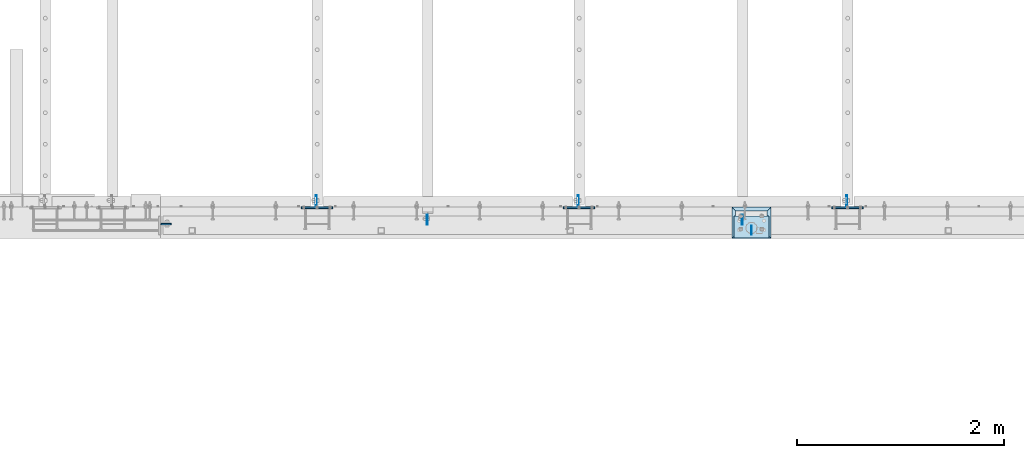
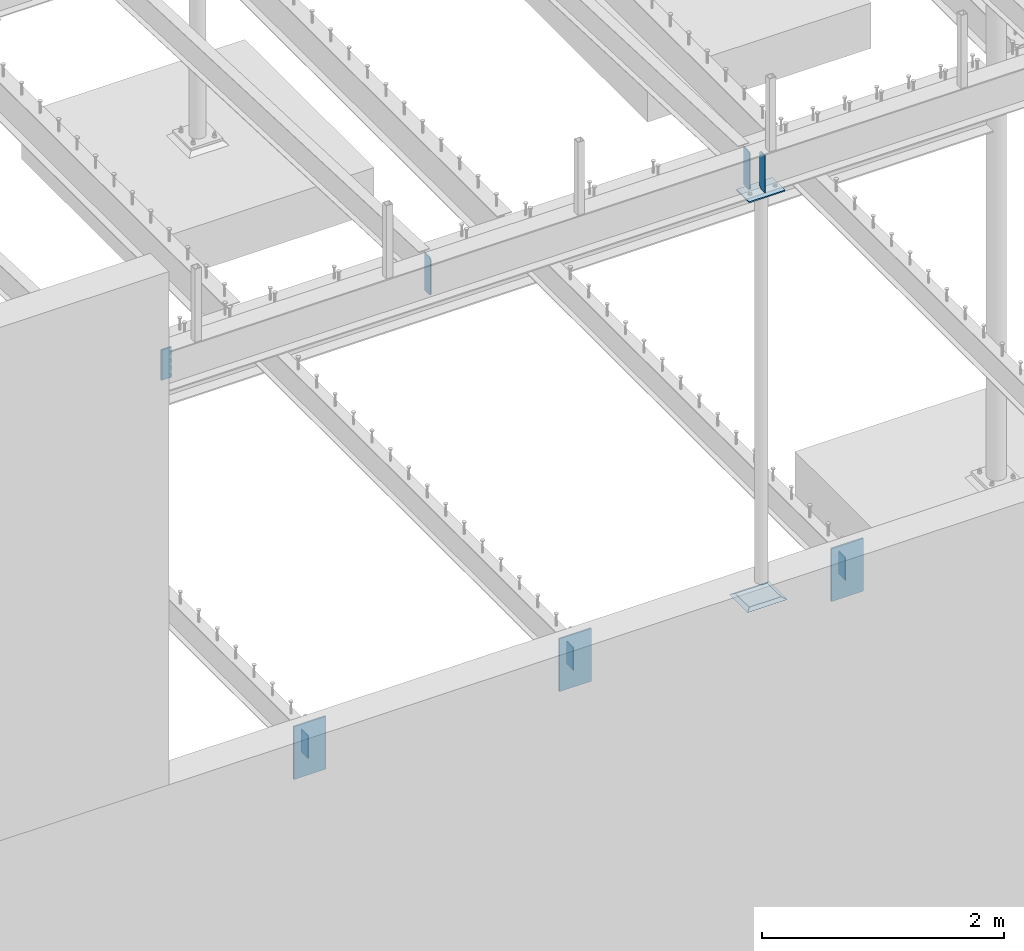
# One storey, part 847 of 975: 12 plates.
"""IFC2X3 building model written with IfcOpenShell, lengths in millimetres."""

from ifc_helpers import new_model, si_unit, frame, origin_with_axes, place, context, subcontext, project, spatial, faceted_brep, material, type_object, element, save


model = new_model("IFC2X3")

# Units and contexts
model_context = context("Model", 3, precision=1e-05, world=origin_with_axes())
body_context = subcontext(model_context, "Body", "Model", "MODEL_VIEW")
ifc_project = project(units=[si_unit("LENGTHUNIT", "METRE", prefix="MILLI"), si_unit("AREAUNIT", "SQUARE_METRE"), si_unit("VOLUMEUNIT", "CUBIC_METRE"), si_unit("MASSUNIT", "GRAM", prefix="KILO"), si_unit("TIMEUNIT", "SECOND"), si_unit("PLANEANGLEUNIT", "RADIAN"), si_unit("SOLIDANGLEUNIT", "STERADIAN"), si_unit("THERMODYNAMICTEMPERATUREUNIT", "DEGREE_CELSIUS"), si_unit("LUMINOUSINTENSITYUNIT", "LUMEN")], contexts=[model_context])

# Site, building, storey
site_placement = place(None, origin_with_axes())
site = spatial("IfcSite", under=ifc_project, at=site_placement, CompositionType="ELEMENT")
building_placement = place(site_placement, origin_with_axes())
building = spatial("IfcBuilding", under=site, at=building_placement, Name="Undefined", CompositionType="ELEMENT")
storey_placement = place(building_placement, origin_with_axes())
storey = spatial("IfcBuildingStorey", under=building, at=storey_placement, Name="Undefined", CompositionType="ELEMENT", Elevation=0.0)

# Plates
ifc_material_1 = material(Name="STEEL/A36")
plate_type_1 = type_object("IfcPlateType", PredefinedType="NOTDEFINED")
for number, where, z_axis, x_axis, name in (
    (1, (14550.2307500839, 130.96875, 8066.68070975216), (0.0, 0.0, 1.0), (0.0, 1.0, 0.0), "PLATE"),
    (2, (17598.2307500839, 130.96875, 8066.68070975215), (0.0, 0.0, 1.0), (0.0, 1.0, 0.0), "PLATE"),
):
    element("IfcPlate", number, at=place(storey_placement, frame(where, z_axis=z_axis, x_axis=x_axis)), inside=storey, type_object=plate_type_1, material=ifc_material_1, Name=name, context=body_context, shape_type="Brep", body=[
        faceted_brep([(0.0, -4.76250000000073, 17.4624996185303), (0.0, -4.76250000000073, 362.944299697877), (0.0, 4.76250000000073, 362.944299697877), (0.0, 4.76250000000073, 17.4624996185303), (17.4624996185303, -4.76250000000073, 380.406799316407), (17.4624996185303, 4.76250000000073, 380.406799316407), (98.4250030517578, -4.76250000000073, 380.406799316407), (98.4250030517578, 4.76250000000073, 380.406799316407), (98.4250030518451, -4.76250000006985, -2.36468622460961e-11), (98.4250030518597, 4.76249999992069, -2.36468622460961e-11), (17.4624996185303, -4.76250000000073, 0.0), (17.4624996185303, 4.76250000000073, 0.0)], [[[0, 1, 2, 3]], [[1, 4, 5, 2]], [[4, 6, 7, 5]], [[6, 8, 9, 7]], [[8, 10, 11, 9]], [[10, 0, 3, 11]], [[5, 7, 9, 11, 3, 2]], [[10, 8, 6, 4, 1, 0]]]),
    ])
plate_type_2 = type_object("IfcPlateType", PredefinedType="NOTDEFINED")
plate_1_placement = place(storey_placement, frame((17687.9249973829, 123.03125, 8447.0875), z_axis=(0.0, 0.0, -1.0), x_axis=(0.0, -1.0, 0.0)))
element("IfcPlate", 3, at=plate_1_placement, inside=storey, type_object=plate_type_2, material=ifc_material_1, Name="PLATE", context=body_context, shape_type="Brep", body=[
    faceted_brep([(0.0, -3.17499999999927, 19.0499992370605), (0.0, -3.17499999999927, 361.950000762939), (0.0, 3.17499999999927, 361.950000762939), (0.0, 3.17499999999927, 19.0499992370605), (19.0499992370605, -3.17499999999927, 381.0), (19.0499992370605, 3.17499999999927, 381.0), (84.9312515258789, -3.17499999999927, 381.0), (84.9312515258789, 3.17499999999927, 381.0), (84.9312515258789, -3.17499999999927, 0.0), (84.9312515258789, 3.17499999999927, 0.0), (19.0499992370605, -3.17499999999927, 0.0), (19.0499992370605, 3.17499999999927, 0.0)], [[[0, 1, 2, 3]], [[1, 4, 5, 2]], [[4, 6, 7, 5]], [[6, 8, 9, 7]], [[8, 10, 11, 9]], [[10, 0, 3, 11]], [[5, 7, 9, 11, 3, 2]], [[10, 8, 6, 4, 1, 0]]]),
])
plate_type_3 = type_object("IfcPlateType", PredefinedType="NOTDEFINED")
plate_2_placement = place(storey_placement, frame((11972.9250113505, 138.90625, 8420.1), z_axis=(1.0, 0.0, 0.0), x_axis=(0.0, 0.0, -1.0)))
element("IfcPlate", 4, at=plate_2_placement, inside=storey, type_object=plate_type_3, material=ifc_material_1, Name="PLATE", context=body_context, shape_type="Brep", body=[
    faceted_brep([(0.0, -7.9375, 7.93699979782104), (0.0, 0.000750202179915505, 0.0), (304.799987792969, 0.000750202179915505, 0.0), (304.799987792969, -7.9375, 7.93699979782104), (304.799987792969, 7.9375, 7.93699979782104), (0.0, 7.9375, 7.93699979782104), (0.0, -7.9375, 101.599998474121), (0.0, 7.9375, 101.599998474121), (304.799987792969, -7.9375, 101.599998474121), (304.799987792969, 7.9375, 101.599998474121)], [[[0, 1, 2, 3]], [[4, 2, 1, 5]], [[6, 7, 5, 1, 0]], [[6, 8, 9, 7]], [[4, 9, 8, 3, 2]], [[7, 9, 4, 5]], [[8, 6, 0, 3]]]),
])
plate_type_4 = type_object("IfcPlateType", PredefinedType="NOTDEFINED")
for number, where, z_axis, x_axis, name in (
    (5, (18610.2625, 304.8, 3898.9), (0.0, 1.0, 0.0), (0.0, 0.0, -1.0), "PLATE"),
    (6, (16013.1125, 304.8, 3898.9), (0.0, 1.0, 0.0), (0.0, 0.0, -1.0), "PLATE"),
    (7, (13479.4625, 304.799999999997, 3898.9), (0.0, 1.0, 0.0), (0.0, 0.0, -1.0), "PLATE"),
):
    element("IfcPlate", number, at=place(storey_placement, frame(where, z_axis=z_axis, x_axis=x_axis)), inside=storey, type_object=plate_type_4, material=ifc_material_1, Name=name, context=body_context, shape_type="Brep", body=[
        faceted_brep([(0.0, -4.76250000000073, 0.0), (0.0, -4.76249999999982, 114.300003051758), (0.0, 4.76249999999982, 114.300003051758), (0.0, 4.76250000000073, 0.0), (228.600006103516, -4.76250000000073, 114.300003051758), (228.600006103516, 4.76250000000073, 114.300003051758), (228.599990844727, -4.76249999999982, 0.0), (228.599990844727, 4.76250000000027, -7.27595761418343e-12)], [[[0, 1, 2, 3]], [[1, 4, 5, 2]], [[4, 6, 7, 5]], [[6, 0, 3, 7]], [[5, 7, 3, 2]], [[6, 4, 1, 0]]]),
    ])
plate_type_5 = type_object("IfcPlateType", PredefinedType="NOTDEFINED")
for number, where, z_axis, x_axis, name in (
    (8, (18465.8, 296.8625, 4048.125), (0.0, 0.0, -1.0), (1.0, 0.0, 0.0), "EMBED"),
    (9, (15868.65, 296.8625, 4048.125), (0.0, 0.0, -1.0), (1.0, 0.0, 0.0), "EMBED"),
    (10, (13335.0, 296.862499999996, 4048.125), (0.0, 0.0, -1.0), (1.0, 0.0, 0.0), "EMBED"),
):
    element("IfcPlate", number, at=place(storey_placement, frame(where, z_axis=z_axis, x_axis=x_axis)), inside=storey, type_object=plate_type_5, material=ifc_material_1, Name=name, context=body_context, shape_type="Brep", body=[
        faceted_brep([(-4.22995071858168e-07, -7.93750000000728, 0.0), (0.0, -7.9375, 533.400024414062), (0.0, 7.9375, 533.400024414062), (4.22980519942939e-07, 7.93750000001091, 0.0), (304.799987792969, -7.9375, 533.400024414062), (304.799987792969, 7.9375, 533.400024414062), (304.799987792969, -7.9375, 0.0), (304.799987792969, 7.9375, 0.0)], [[[0, 1, 2, 3]], [[1, 4, 5, 2]], [[4, 6, 7, 5]], [[6, 0, 3, 7]], [[5, 7, 3, 2]], [[6, 4, 1, 0]]]),
    ])
plate_type_6 = type_object("IfcPlateType", PredefinedType="NOTDEFINED")
plate_3_placement = place(storey_placement, frame((17859.3749973829, 216.693749669799, 8048.625), z_axis=(-0.999999999999998, 6.90000001668524e-08, 0.0), x_axis=(0.0, -1.0, 0.0)))
element("IfcPlate", 11, at=plate_3_placement, inside=storey, type_object=plate_type_6, material=ifc_material_1, Name="PLATE", context=body_context, shape_type="Brep", body=[
    faceted_brep([(0.0, -6.34999999998763, -3.63797880709171e-12), (-4.32919478043914e-10, -6.34999999999991, 342.899993895661), (-4.32919478043914e-10, 6.34999999999991, 342.899993895661), (0.0, 6.34999999999491, 5.45696821063757e-12), (211.137496948242, -6.35000000000036, 342.899993896484), (211.137496948242, 6.35000000000036, 342.899993896484), (211.137496948242, -6.35000000000036, 0.0), (211.137496948242, 6.35000000000036, 0.0)], [[[0, 1, 2, 3]], [[1, 4, 5, 2]], [[4, 6, 7, 5]], [[6, 0, 3, 7]], [[5, 7, 3, 2]], [[6, 4, 1, 0]]]),
])
ifc_material_2 = material(Name="CONCRETE/GROUT")
plate_type_7 = type_object("IfcPlateType", PredefinedType="NOTDEFINED")
plate_4_placement = place(storey_placement, frame((17878.424996684, 7.99495531111916e-07, 3927.475), z_axis=(-0.999999999999998, 6.90000001668524e-08, 0.0), x_axis=(0.0, 1.0, 0.0)))
element("IfcPlate", 12, at=plate_4_placement, inside=storey, type_object=plate_type_7, material=ifc_material_2, Name="GROUT", context=body_context, shape_type="Brep", body=[
    faceted_brep([(38.1000053333363, -9.52500071984969, 342.900001116637), (1.04259142972296e-05, 9.52500000000009, 380.999938964844), (0.0, 9.52499999999964, 0.0), (38.100001802739, -9.52500001320686, 38.0999998895832), (304.799983490262, 9.52500028772283, 380.999930988021), (266.700003939163, -9.52500001027192, 342.89999509497), (266.700000408565, -9.52500009244795, 38.0999938679161), (304.799957275391, 9.52500000000009, 5.82076609134674e-11)], [[[0, 1, 2, 3]], [[4, 5, 6, 7]], [[6, 5, 0, 3]], [[7, 6, 3, 2]], [[4, 7, 2, 1]], [[5, 4, 1, 0]]]),
])

save(model, "model.ifc")
